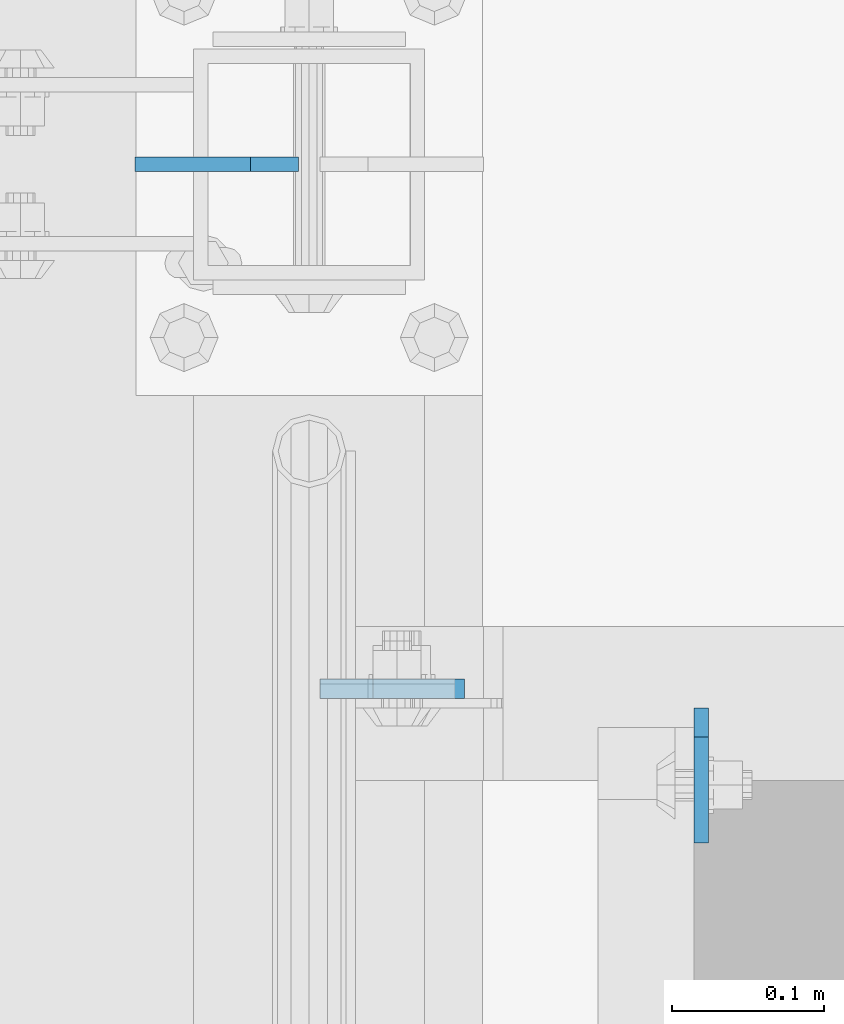
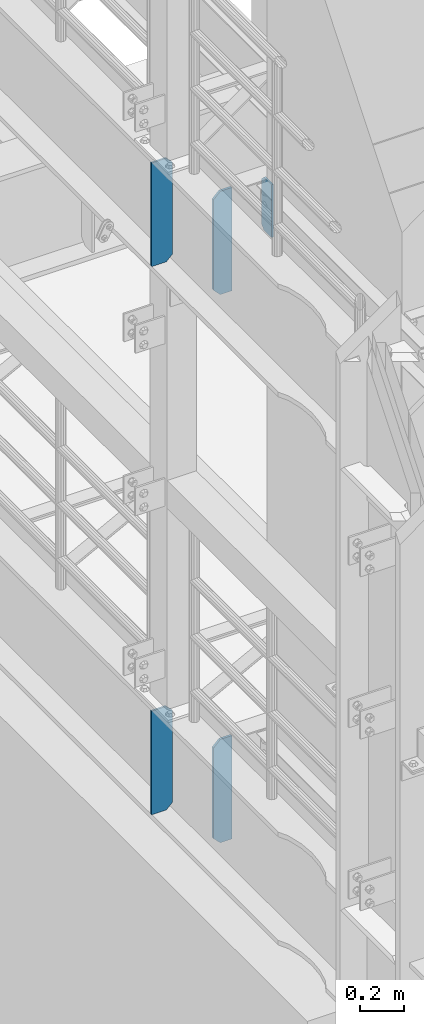
# One storey, part 1601 of 1876: 5 plates, 3 elements without a shape of their own.
"""IFC2X3 building model written with IfcOpenShell, lengths in millimetres."""

from ifc_helpers import new_model, si_unit, frame, origin_with_axes, place, context, subcontext, project, spatial, faceted_brep, material, type_object, element, aggregate, save


model = new_model("IFC2X3")

# Units and contexts
model_context = context("Model", 3, precision=1e-05, world=origin_with_axes())
body_context = subcontext(model_context, "Body", "Model", "MODEL_VIEW")
ifc_project = project(units=[si_unit("LENGTHUNIT", "METRE", prefix="MILLI"), si_unit("AREAUNIT", "SQUARE_METRE"), si_unit("VOLUMEUNIT", "CUBIC_METRE"), si_unit("MASSUNIT", "GRAM", prefix="KILO"), si_unit("TIMEUNIT", "SECOND"), si_unit("PLANEANGLEUNIT", "RADIAN"), si_unit("SOLIDANGLEUNIT", "STERADIAN"), si_unit("THERMODYNAMICTEMPERATUREUNIT", "DEGREE_CELSIUS"), si_unit("LUMINOUSINTENSITYUNIT", "LUMEN")], contexts=[model_context])

# Site, building, storey
site_placement = place(None, origin_with_axes())
site = spatial("IfcSite", under=ifc_project, at=site_placement, CompositionType="ELEMENT")
building_placement = place(site_placement, origin_with_axes())
building = spatial("IfcBuilding", under=site, at=building_placement, Name="Undefined", CompositionType="ELEMENT")
storey_placement = place(building_placement, origin_with_axes())
storey = spatial("IfcBuildingStorey", under=building, at=storey_placement, Name="Undefined", CompositionType="ELEMENT", Elevation=0.0)

# Assembly, plate
assembly_1_placement = place(storey_placement, origin_with_axes())
assembly_1 = element("IfcElementAssembly", 1, at=assembly_1_placement, inside=storey, Name="BEAM", AssemblyPlace="NOTDEFINED", PredefinedType="RIGID_FRAME")
ifc_material = material(Name="STEEL/A36")
plate_type_1 = type_object("IfcPlateType", PredefinedType="NOTDEFINED")
plate_1_placement = place(assembly_1_placement, frame((258.762999916077, 3197.225, 7856.5375), z_axis=(0.0, 0.0, 1.0), x_axis=(0.0, -1.0, 0.0)))
plate_1 = element("IfcPlate", 2, at=plate_1_placement, type_object=plate_type_1, material=ifc_material, Name="PLATE", context=body_context, shape_type="Brep", body=[
    faceted_brep([(0.0, -4.76249999999982, 19.0499992370605), (0.0, -4.76249999999982, 271.462512969971), (0.0, 4.76249999999982, 271.462512969971), (0.0, 4.76249999999982, 19.0499992370605), (19.0499992370605, -4.76249999999982, 290.512512207031), (19.0499992370605, 4.76249999999982, 290.512512207031), (88.9000015258789, -4.76249999999982, 290.512512207031), (88.9000015258789, 4.76249999999982, 290.512512207031), (88.9000015258789, -4.76249999999982, 0.0), (88.9000015258789, 4.76249999999982, 0.0), (19.0499992370605, -4.76249999999982, 0.0), (19.0499992370605, 4.76249999999982, 0.0)], [[[0, 1, 2, 3]], [[1, 4, 5, 2]], [[4, 6, 7, 5]], [[6, 8, 9, 7]], [[8, 10, 11, 9]], [[10, 0, 3, 11]], [[5, 7, 9, 11, 3, 2]], [[10, 8, 6, 4, 1, 0]]]),
])
aggregate(assembly_1, [plate_1])

assembly_2_placement = place(storey_placement, origin_with_axes())
assembly_2 = element("IfcElementAssembly", 3, at=assembly_2_placement, inside=storey, Name="BEAM", AssemblyPlace="NOTDEFINED", PredefinedType="RIGID_FRAME")
plate_type_2 = type_object("IfcPlateType", PredefinedType="NOTDEFINED")
plate_2_placement = place(assembly_2_placement, frame((7.14374999999999, 3209.92500009537, 7558.0875), z_axis=(0.0, 0.0, 1.0), x_axis=(1.0, 0.0, 0.0)))
plate_2 = element("IfcPlate", 4, at=plate_2_placement, type_object=plate_type_2, material=ifc_material, Name="PLATE", context=body_context, shape_type="Brep", body=[
    faceted_brep([(0.0, -6.34999999999991, 34.9249992370605), (0.0, -6.34999999999991, 534.987476348877), (0.0, 6.34999999999991, 534.987476348877), (0.0, 6.34999999999991, 34.9249992370605), (34.9249992370605, -6.34999999999991, 569.912475585938), (34.9249992370605, 6.34999999999991, 569.912475585938), (95.25, -6.35000000000036, 569.912475585938), (95.25, 6.35000000000036, 569.912475585938), (95.25, -6.35000000000036, 0.0), (95.25, 6.35000000000036, 0.0), (34.9249992370605, -6.34999999999991, 0.0), (34.9249992370605, 6.34999999999991, 0.0)], [[[0, 1, 2, 3]], [[1, 4, 5, 2]], [[4, 6, 7, 5]], [[6, 8, 9, 7]], [[8, 10, 11, 9]], [[10, 0, 3, 11]], [[5, 7, 9, 11, 3, 2]], [[10, 8, 6, 4, 1, 0]]]),
])

assembly_3_placement = place(storey_placement, origin_with_axes())
assembly_3 = element("IfcElementAssembly", 5, at=assembly_3_placement, inside=storey, Name="BEAM", AssemblyPlace="NOTDEFINED", PredefinedType="RIGID_FRAME")
plate_3_placement = place(assembly_3_placement, frame((7.14374999999999, 3209.92500009537, 4535.4875), z_axis=(0.0, 0.0, 1.0), x_axis=(1.0, 0.0, 0.0)))
plate_3 = element("IfcPlate", 6, at=plate_3_placement, type_object=plate_type_2, material=ifc_material, Name="PLATE", context=body_context, shape_type="Brep", body=[
    faceted_brep([(0.0, -6.34999999999991, 34.9249992370605), (0.0, -6.34999999999991, 534.987476348877), (0.0, 6.34999999999991, 534.987476348877), (0.0, 6.34999999999991, 34.9249992370605), (34.9249992370605, -6.34999999999991, 569.912475585938), (34.9249992370605, 6.34999999999991, 569.912475585938), (95.25, -6.35000000000036, 569.912475585938), (95.25, 6.35000000000036, 569.912475585938), (95.25, -6.35000000000036, 0.0), (95.25, 6.35000000000036, 0.0), (34.9249992370605, -6.34999999999991, 0.0), (34.9249992370605, 6.34999999999991, 0.0)], [[[0, 1, 2, 3]], [[1, 4, 5, 2]], [[4, 6, 7, 5]], [[6, 8, 9, 7]], [[8, 10, 11, 9]], [[10, 0, 3, 11]], [[5, 7, 9, 11, 3, 2]], [[10, 8, 6, 4, 1, 0]]]),
])

# Plate
plate_type_3 = type_object("IfcPlateType", PredefinedType="NOTDEFINED")
plate_4_placement = place(assembly_2_placement, frame((-7.14374999999999, 3556.0, 7556.5), z_axis=(0.0, 0.0, 1.0), x_axis=(-1.0, 0.0, 0.0)))
plate_4 = element("IfcPlate", 7, at=plate_4_placement, type_object=plate_type_3, material=ifc_material, Name="PLATE", context=body_context, shape_type="Brep", body=[
    faceted_brep([(-9.76996261670138e-14, -4.76250000000073, 31.75), (0.0, -4.76249999999982, 539.75), (0.0, 4.76249999999982, 539.75), (-9.76996261670138e-14, 4.76250000000073, 31.75), (31.75, -4.76249999999982, 571.5), (31.75, 4.76249999999982, 571.5), (107.949996948242, -4.76249999999982, 571.5), (107.949996948242, 4.76249999999982, 571.5), (107.950006484985, -4.76250000000073, 0.0), (107.950006484985, 4.76250000000073, 0.0), (31.75, -4.76250000000073, 0.0), (31.75, 4.76250000000073, 0.0)], [[[0, 1, 2, 3]], [[1, 4, 5, 2]], [[4, 6, 7, 5]], [[6, 8, 9, 7]], [[8, 10, 11, 9]], [[10, 0, 3, 11]], [[5, 7, 9, 11, 3, 2]], [[10, 8, 6, 4, 1, 0]]]),
])

aggregate(assembly_2, [plate_4, plate_2])

plate_5_placement = place(assembly_3_placement, frame((-7.14374999999999, 3556.0, 4533.9), z_axis=(0.0, 0.0, 1.0), x_axis=(-1.0, 0.0, 0.0)))
plate_5 = element("IfcPlate", 8, at=plate_5_placement, type_object=plate_type_3, material=ifc_material, Name="PLATE", context=body_context, shape_type="Brep", body=[
    faceted_brep([(-9.76996261670138e-14, -4.76250000000073, 31.75), (0.0, -4.76249999999982, 539.75), (0.0, 4.76249999999982, 539.75), (-9.76996261670138e-14, 4.76250000000073, 31.75), (31.75, -4.76249999999982, 571.5), (31.75, 4.76249999999982, 571.5), (107.949996948242, -4.76249999999982, 571.5), (107.949996948242, 4.76249999999982, 571.5), (107.950006484985, -4.76250000000073, 0.0), (107.950006484985, 4.76250000000073, 0.0), (31.75, -4.76250000000073, 0.0), (31.75, 4.76250000000073, 0.0)], [[[0, 1, 2, 3]], [[1, 4, 5, 2]], [[4, 6, 7, 5]], [[6, 8, 9, 7]], [[8, 10, 11, 9]], [[10, 0, 3, 11]], [[5, 7, 9, 11, 3, 2]], [[10, 8, 6, 4, 1, 0]]]),
])

aggregate(assembly_3, [plate_5, plate_3])

save(model, "model.ifc")
